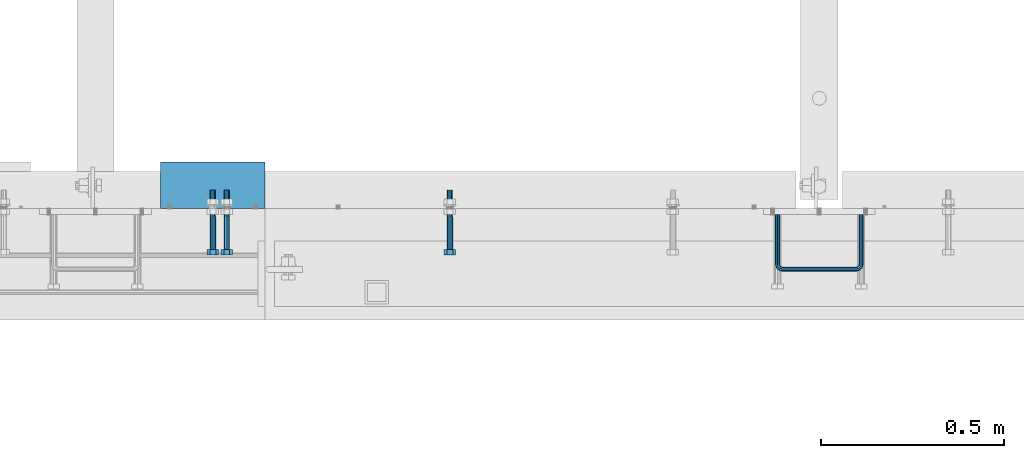
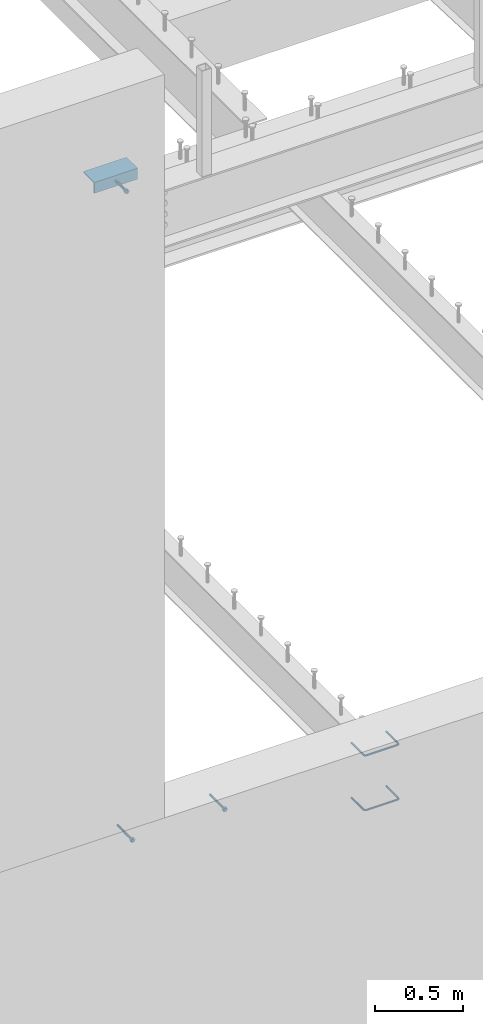
# One storey, part 400 of 975: 6 beams.
"""IFC2X3 building model written with IfcOpenShell, lengths in millimetres."""

from ifc_helpers import new_model, si_unit, frame, origin_with_axes, place, context, subcontext, project, spatial, faceted_brep, material, type_object, element, save


model = new_model("IFC2X3")

# Units and contexts
model_context = context("Model", 3, precision=1e-05, world=origin_with_axes())
body_context = subcontext(model_context, "Body", "Model", "MODEL_VIEW")
ifc_project = project(units=[si_unit("LENGTHUNIT", "METRE", prefix="MILLI"), si_unit("AREAUNIT", "SQUARE_METRE"), si_unit("VOLUMEUNIT", "CUBIC_METRE"), si_unit("MASSUNIT", "GRAM", prefix="KILO"), si_unit("TIMEUNIT", "SECOND"), si_unit("PLANEANGLEUNIT", "RADIAN"), si_unit("SOLIDANGLEUNIT", "STERADIAN"), si_unit("THERMODYNAMICTEMPERATUREUNIT", "DEGREE_CELSIUS"), si_unit("LUMINOUSINTENSITYUNIT", "LUMEN")], contexts=[model_context])

# Site, building, storey
site_placement = place(None, origin_with_axes())
site = spatial("IfcSite", under=ifc_project, at=site_placement, CompositionType="ELEMENT")
building_placement = place(site_placement, origin_with_axes())
building = spatial("IfcBuilding", under=site, at=building_placement, Name="Undefined", CompositionType="ELEMENT")
storey_placement = place(building_placement, origin_with_axes())
storey = spatial("IfcBuildingStorey", under=building, at=storey_placement, Name="Undefined", CompositionType="ELEMENT", Elevation=0.0)

# Beams
ifc_material_1 = material(Name="STEEL/F1554-36")
beam_type_1 = type_object("IfcBeamType", PredefinedType="NOTDEFINED")
beam_1_placement = place(storey_placement, frame((11830.0499551931, 282.575168162621, 8420.10000031656), z_axis=(0.0, 0.0, -1.0), x_axis=(-1.08499996598766e-06, -0.999999999999411, 3.99994337564561e-09)))
element("IfcBeam", 1, at=beam_1_placement, inside=storey, type_object=beam_type_1, material=ifc_material_1, Name="HEADED_ANCHOR_BOLT", context=body_context, shape_type="Brep", body=[
    faceted_brep([(88.9000000184824, 7.94000001861696, -13.7499999799138), (88.8999999527368, 15.8800000758411, 2.00943759409711e-08), (104.774999952569, 15.8800001213949, 6.97191353538074e-08), (104.775000018315, 7.94000006417082, -13.7499999302891), (88.900000064019, -7.94000009583215, -13.7499999799147), (104.775000063852, -7.9400000502792, -13.74999993029), (88.9000000438027, -15.880000153059, 2.00925569515675e-08), (104.775000043643, -15.8800001075042, 6.9716406869702e-08), (88.8999999780608, -7.94000009583488, 13.7500000200998), (104.774999977893, -7.94000005028101, 13.7500000697237), (88.8999999325279, 7.94000001861514, 13.7500000201007), (104.774999932361, 7.940000064169, 13.7500000697246), (88.9000000119959, 3.78780480527439, -7.86545778426807), (88.8999999957159, 6.82538844544797, -5.4430656647246), (88.8999999799416, 8.51112018845743, -1.94260763148395), (88.8999999677944, 8.51112018845652, 1.94260767167179), (88.8999999616899, 6.82538844544615, 5.44306570491244), (88.8999999628249, 3.78780480527257, 7.86545782445592), (88.8999999709849, -3.86089595849626e-08, 8.72999956233434), (88.8999999845473, -3.7878048824914, 7.8654578244541), (88.9000000008309, -6.82538852266407, 5.44306570491153), (88.9000000166052, -8.51112026567444, 1.94260767166998), (88.9000000287488, -8.51112026567353, -1.94260763148577), (88.9000000348606, -6.82538852266407, -5.44306566472642), (88.9000000337182, -3.78780488248958, -7.86545778426898), (88.9000000255583, -3.86080500902608e-08, -8.72999952214832), (104.775000025395, 6.94581103743985e-09, -8.72999947252447), (104.775000011829, 3.78780485082825, -7.86545773464422), (104.774999995549, 6.82538849100092, -5.44306561510075), (104.774999979774, 8.51112023401038, -1.9426075818601), (104.774999967627, 8.51112023401038, 1.94260772129564), (104.774999961523, 6.82538849100092, 5.44306575453629), (104.774999962658, 3.78780485082643, 7.86545787407977), (104.774999970818, 6.94399204803631e-09, 8.7299996119591), (104.77499998438, -3.78780483693754, 7.86545787407886), (104.775000000664, -6.82538847711112, 5.44306575453538), (104.775000016438, -8.51112022012057, 1.94260772129473), (104.775000028581, -8.51112022012057, -1.94260758186101), (104.775000034693, -6.82538847711021, -5.44306561510166), (104.775000033551, -3.78780483693663, -7.86545773464422), (-2.99107341561466e-07, -5.61266007567065, 5.61266007566792), (-4.22995071858168e-07, -7.93750000000728, 0.0), (104.774999998088, -7.93749999999, -4.45652403868735e-11), (104.774999998088, -5.61266007565791, 5.61266007562426), (-1.09139364212751e-11, 1.81898940354586e-12, 7.9375), (104.774999998095, 1.18234311230481e-11, 7.93749999995816), (2.99089151667431e-07, 5.61266007567428, 5.61266007566792), (104.774999998102, 5.61266007568065, 5.61266007562517), (4.22980519942939e-07, 7.93750000001091, 0.0), (104.77499999811, 7.93750000001364, -4.36557456851006e-11), (2.99089151667431e-07, 5.61266007567428, -5.61266007566792), (104.774999998102, 5.61266007568156, -5.61266007571339), (-1.09139364212751e-11, 1.81898940354586e-12, -7.9375), (104.774999998099, 1.2732925824821e-11, -7.93750000004547), (-73.0249999592124, 5.05157065939329, -5.0515715445581), (-73.0249999269472, -1.85405951924622e-07, -7.14400069976364), (-73.0249999328516, -5.0515710302052, -5.05157154455992), (-73.0249999734697, -7.14400018541073, -6.9975976657588e-07), (-73.0250000250016, -5.05157103020611, 5.05157014504039), (-73.0250000572705, -1.85406861419324e-07, 7.1439993002441), (-73.0250000513661, 5.05157065939238, 5.05157014503948), (-73.025000010748, 7.14399981459792, -6.99758857081179e-07), (0.00625003290042514, 5.05157085007795, -5.05157087849238), (0.00625006516929716, 5.27870724909008e-09, -7.1440000336961), (0.00625005926485755, -5.05157083952145, -5.05157087849329), (0.00625001864682417, -7.14399999472516, -3.36940502165817e-08), (0.00624996711121639, -5.05157083952145, 5.05157081110519), (0.00624993484598235, 5.2777977543883e-09, 7.14399996631164), (0.00624994074678398, 5.05157085007704, 5.05157081110701), (0.00624998136845534, 7.14400000528167, -3.36922312271781e-08), (-2.99107341561466e-07, -5.61266007567065, -5.61266007566792), (104.774999998092, -5.612660075657, -5.6126600757143)], [[[0, 1, 2, 3]], [[4, 0, 3, 5]], [[6, 4, 5, 7]], [[8, 6, 7, 9]], [[10, 8, 9, 11]], [[0, 4, 6, 8, 10, 1], [12, 13, 14, 15, 16, 17, 18, 19, 20, 21, 22, 23, 24, 25]], [[12, 25, 26, 27]], [[13, 12, 27, 28]], [[14, 13, 28, 29]], [[15, 14, 29, 30]], [[16, 15, 30, 31]], [[17, 16, 31, 32]], [[18, 17, 32, 33]], [[19, 18, 33, 34]], [[20, 19, 34, 35]], [[21, 20, 35, 36]], [[22, 21, 36, 37]], [[23, 22, 37, 38]], [[24, 23, 38, 39]], [[25, 24, 39, 26]], [[9, 7, 5, 3, 2, 11], [38, 37, 36, 35, 34, 33, 32, 31, 30, 29, 28, 27, 26, 39]], [[1, 10, 11, 2]], [[40, 41, 42, 43]], [[44, 40, 43, 45]], [[46, 44, 45, 47]], [[48, 46, 47, 49]], [[50, 48, 49, 51]], [[52, 50, 51, 53]], [[54, 55, 56, 57, 58, 59, 60, 61]], [[55, 54, 62, 63]], [[56, 55, 63, 64]], [[57, 56, 64, 65]], [[58, 57, 65, 66]], [[59, 58, 66, 67]], [[60, 59, 67, 68]], [[61, 60, 68, 69]], [[54, 61, 69, 62]], [[40, 44, 46, 48, 50, 52, 70, 41], [68, 67, 66, 65, 64, 63, 62, 69]], [[41, 70, 71, 42]], [[53, 51, 49, 47, 45, 43, 42, 71]], [[70, 52, 53, 71]]]),
])
beam_2_placement = place(storey_placement, frame((11868.15, 282.574999999997, 3886.2), z_axis=(0.0, 0.0, -1.0), x_axis=(0.0, -1.0, 0.0)))
element("IfcBeam", 2, at=beam_2_placement, inside=storey, type_object=beam_type_1, material=ifc_material_1, Name="HEADED_ANCHOR_BOLT", context=body_context, shape_type="Brep", body=[
    faceted_brep([(88.9000000184824, 7.94000001861696, -13.7499999799138), (88.8999999527368, 15.8800000758411, 2.00943759409711e-08), (104.774999952569, 15.8800001213949, 6.97191353538074e-08), (104.775000018315, 7.94000006417082, -13.7499999302891), (88.900000064019, -7.94000009583215, -13.7499999799147), (104.775000063852, -7.9400000502792, -13.74999993029), (88.9000000438027, -15.880000153059, 2.00925569515675e-08), (104.775000043643, -15.8800001075042, 6.9716406869702e-08), (88.8999999780608, -7.94000009583488, 13.7500000200998), (104.774999977893, -7.94000005028101, 13.7500000697237), (88.8999999325279, 7.94000001861514, 13.7500000201007), (104.774999932361, 7.940000064169, 13.7500000697246), (88.9000000119959, 3.78780480527439, -7.86545778426807), (88.8999999957159, 6.82538844544797, -5.4430656647246), (88.8999999799416, 8.51112018845743, -1.94260763148395), (88.8999999677944, 8.51112018845652, 1.94260767167179), (88.8999999616899, 6.82538844544615, 5.44306570491244), (88.8999999628249, 3.78780480527257, 7.86545782445592), (88.8999999709849, -3.86089595849626e-08, 8.72999956233434), (88.8999999845473, -3.7878048824914, 7.8654578244541), (88.9000000008309, -6.82538852266407, 5.44306570491153), (88.9000000166052, -8.51112026567444, 1.94260767166998), (88.9000000287488, -8.51112026567353, -1.94260763148577), (88.9000000348606, -6.82538852266407, -5.44306566472642), (88.9000000337182, -3.78780488248958, -7.86545778426898), (88.9000000255583, -3.86080500902608e-08, -8.72999952214832), (104.775000025395, 6.94581103743985e-09, -8.72999947252447), (104.775000011829, 3.78780485082825, -7.86545773464422), (104.774999995549, 6.82538849100092, -5.44306561510075), (104.774999979774, 8.51112023401038, -1.9426075818601), (104.774999967627, 8.51112023401038, 1.94260772129564), (104.774999961523, 6.82538849100092, 5.44306575453629), (104.774999962658, 3.78780485082643, 7.86545787407977), (104.774999970818, 6.94399204803631e-09, 8.7299996119591), (104.77499998438, -3.78780483693754, 7.86545787407886), (104.775000000664, -6.82538847711112, 5.44306575453538), (104.775000016438, -8.51112022012057, 1.94260772129473), (104.775000028581, -8.51112022012057, -1.94260758186101), (104.775000034693, -6.82538847711021, -5.44306561510166), (104.775000033551, -3.78780483693663, -7.86545773464422), (-2.99107341561466e-07, -5.61266007567065, 5.61266007566792), (-4.22995071858168e-07, -7.93750000000728, 0.0), (104.774999998088, -7.93749999999, -4.45652403868735e-11), (104.774999998088, -5.61266007565791, 5.61266007562426), (-1.09139364212751e-11, 1.81898940354586e-12, 7.9375), (104.774999998095, 1.18234311230481e-11, 7.93749999995816), (2.99089151667431e-07, 5.61266007567428, 5.61266007566792), (104.774999998102, 5.61266007568065, 5.61266007562517), (4.22980519942939e-07, 7.93750000001091, 0.0), (104.77499999811, 7.93750000001364, -4.36557456851006e-11), (2.99089151667431e-07, 5.61266007567428, -5.61266007566792), (104.774999998102, 5.61266007568156, -5.61266007571339), (-1.09139364212751e-11, 1.81898940354586e-12, -7.9375), (104.774999998099, 1.2732925824821e-11, -7.93750000004547), (-73.0249999592124, 5.05157065939329, -5.0515715445581), (-73.0249999269472, -1.85405951924622e-07, -7.14400069976364), (-73.0249999328516, -5.0515710302052, -5.05157154455992), (-73.0249999734697, -7.14400018541073, -6.9975976657588e-07), (-73.0250000250016, -5.05157103020611, 5.05157014504039), (-73.0250000572705, -1.85406861419324e-07, 7.1439993002441), (-73.0250000513661, 5.05157065939238, 5.05157014503948), (-73.025000010748, 7.14399981459792, -6.99758857081179e-07), (0.00625003290042514, 5.05157085007795, -5.05157087849238), (0.00625006516929716, 5.27870724909008e-09, -7.1440000336961), (0.00625005926485755, -5.05157083952145, -5.05157087849329), (0.00625001864682417, -7.14399999472516, -3.36940502165817e-08), (0.00624996711121639, -5.05157083952145, 5.05157081110519), (0.00624993484598235, 5.2777977543883e-09, 7.14399996631164), (0.00624994074678398, 5.05157085007704, 5.05157081110701), (0.00624998136845534, 7.14400000528167, -3.36922312271781e-08), (-2.99107341561466e-07, -5.61266007567065, -5.61266007566792), (104.774999998092, -5.612660075657, -5.6126600757143)], [[[0, 1, 2, 3]], [[4, 0, 3, 5]], [[6, 4, 5, 7]], [[8, 6, 7, 9]], [[10, 8, 9, 11]], [[0, 4, 6, 8, 10, 1], [12, 13, 14, 15, 16, 17, 18, 19, 20, 21, 22, 23, 24, 25]], [[12, 25, 26, 27]], [[13, 12, 27, 28]], [[14, 13, 28, 29]], [[15, 14, 29, 30]], [[16, 15, 30, 31]], [[17, 16, 31, 32]], [[18, 17, 32, 33]], [[19, 18, 33, 34]], [[20, 19, 34, 35]], [[21, 20, 35, 36]], [[22, 21, 36, 37]], [[23, 22, 37, 38]], [[24, 23, 38, 39]], [[25, 24, 39, 26]], [[9, 7, 5, 3, 2, 11], [38, 37, 36, 35, 34, 33, 32, 31, 30, 29, 28, 27, 26, 39]], [[1, 10, 11, 2]], [[40, 41, 42, 43]], [[44, 40, 43, 45]], [[46, 44, 45, 47]], [[48, 46, 47, 49]], [[50, 48, 49, 51]], [[52, 50, 51, 53]], [[54, 55, 56, 57, 58, 59, 60, 61]], [[55, 54, 62, 63]], [[56, 55, 63, 64]], [[57, 56, 64, 65]], [[58, 57, 65, 66]], [[59, 58, 66, 67]], [[60, 59, 67, 68]], [[61, 60, 68, 69]], [[54, 61, 69, 62]], [[40, 44, 46, 48, 50, 52, 70, 41], [68, 67, 66, 65, 64, 63, 62, 69]], [[41, 70, 71, 42]], [[53, 51, 49, 47, 45, 43, 42, 71]], [[70, 52, 53, 71]]]),
])
beam_3_placement = place(storey_placement, frame((12477.75, 282.574999999997, 3886.2), z_axis=(0.0, 0.0, 1.0), x_axis=(0.0, -1.0, 0.0)))
element("IfcBeam", 3, at=beam_3_placement, inside=storey, type_object=beam_type_1, material=ifc_material_1, Name="HEADED_ANCHOR_BOLT", context=body_context, shape_type="Brep", body=[
    faceted_brep([(88.9000000184824, 7.94000001861696, -13.7499999799138), (88.8999999527368, 15.8800000758411, 2.00943759409711e-08), (104.774999952569, 15.8800001213949, 6.97191353538074e-08), (104.775000018315, 7.94000006417082, -13.7499999302891), (88.900000064019, -7.94000009583215, -13.7499999799147), (104.775000063852, -7.9400000502792, -13.74999993029), (88.9000000438027, -15.880000153059, 2.00925569515675e-08), (104.775000043643, -15.8800001075042, 6.9716406869702e-08), (88.8999999780608, -7.94000009583488, 13.7500000200998), (104.774999977893, -7.94000005028101, 13.7500000697237), (88.8999999325279, 7.94000001861514, 13.7500000201007), (104.774999932361, 7.940000064169, 13.7500000697246), (88.9000000119959, 3.78780480527439, -7.86545778426807), (88.8999999957159, 6.82538844544797, -5.4430656647246), (88.8999999799416, 8.51112018845743, -1.94260763148395), (88.8999999677944, 8.51112018845652, 1.94260767167179), (88.8999999616899, 6.82538844544615, 5.44306570491244), (88.8999999628249, 3.78780480527257, 7.86545782445592), (88.8999999709849, -3.86089595849626e-08, 8.72999956233434), (88.8999999845473, -3.7878048824914, 7.8654578244541), (88.9000000008309, -6.82538852266407, 5.44306570491153), (88.9000000166052, -8.51112026567444, 1.94260767166998), (88.9000000287488, -8.51112026567353, -1.94260763148577), (88.9000000348606, -6.82538852266407, -5.44306566472642), (88.9000000337182, -3.78780488248958, -7.86545778426898), (88.9000000255583, -3.86080500902608e-08, -8.72999952214832), (104.775000025395, 6.94581103743985e-09, -8.72999947252447), (104.775000011829, 3.78780485082825, -7.86545773464422), (104.774999995549, 6.82538849100092, -5.44306561510075), (104.774999979774, 8.51112023401038, -1.9426075818601), (104.774999967627, 8.51112023401038, 1.94260772129564), (104.774999961523, 6.82538849100092, 5.44306575453629), (104.774999962658, 3.78780485082643, 7.86545787407977), (104.774999970818, 6.94399204803631e-09, 8.7299996119591), (104.77499998438, -3.78780483693754, 7.86545787407886), (104.775000000664, -6.82538847711112, 5.44306575453538), (104.775000016438, -8.51112022012057, 1.94260772129473), (104.775000028581, -8.51112022012057, -1.94260758186101), (104.775000034693, -6.82538847711021, -5.44306561510166), (104.775000033551, -3.78780483693663, -7.86545773464422), (-2.99107341561466e-07, -5.61266007567065, 5.61266007566792), (-4.22995071858168e-07, -7.93750000000728, 0.0), (104.774999998088, -7.93749999999, -4.45652403868735e-11), (104.774999998088, -5.61266007565791, 5.61266007562426), (-1.09139364212751e-11, 1.81898940354586e-12, 7.9375), (104.774999998095, 1.18234311230481e-11, 7.93749999995816), (2.99089151667431e-07, 5.61266007567428, 5.61266007566792), (104.774999998102, 5.61266007568065, 5.61266007562517), (4.22980519942939e-07, 7.93750000001091, 0.0), (104.77499999811, 7.93750000001364, -4.36557456851006e-11), (2.99089151667431e-07, 5.61266007567428, -5.61266007566792), (104.774999998102, 5.61266007568156, -5.61266007571339), (-1.09139364212751e-11, 1.81898940354586e-12, -7.9375), (104.774999998099, 1.2732925824821e-11, -7.93750000004547), (-73.0249999592124, 5.05157065939329, -5.0515715445581), (-73.0249999269472, -1.85405951924622e-07, -7.14400069976364), (-73.0249999328516, -5.0515710302052, -5.05157154455992), (-73.0249999734697, -7.14400018541073, -6.9975976657588e-07), (-73.0250000250016, -5.05157103020611, 5.05157014504039), (-73.0250000572705, -1.85406861419324e-07, 7.1439993002441), (-73.0250000513661, 5.05157065939238, 5.05157014503948), (-73.025000010748, 7.14399981459792, -6.99758857081179e-07), (0.00625003290042514, 5.05157085007795, -5.05157087849238), (0.00625006516929716, 5.27870724909008e-09, -7.1440000336961), (0.00625005926485755, -5.05157083952145, -5.05157087849329), (0.00625001864682417, -7.14399999472516, -3.36940502165817e-08), (0.00624996711121639, -5.05157083952145, 5.05157081110519), (0.00624993484598235, 5.2777977543883e-09, 7.14399996631164), (0.00624994074678398, 5.05157085007704, 5.05157081110701), (0.00624998136845534, 7.14400000528167, -3.36922312271781e-08), (-2.99107341561466e-07, -5.61266007567065, -5.61266007566792), (104.774999998092, -5.612660075657, -5.6126600757143)], [[[0, 1, 2, 3]], [[4, 0, 3, 5]], [[6, 4, 5, 7]], [[8, 6, 7, 9]], [[10, 8, 9, 11]], [[0, 4, 6, 8, 10, 1], [12, 13, 14, 15, 16, 17, 18, 19, 20, 21, 22, 23, 24, 25]], [[12, 25, 26, 27]], [[13, 12, 27, 28]], [[14, 13, 28, 29]], [[15, 14, 29, 30]], [[16, 15, 30, 31]], [[17, 16, 31, 32]], [[18, 17, 32, 33]], [[19, 18, 33, 34]], [[20, 19, 34, 35]], [[21, 20, 35, 36]], [[22, 21, 36, 37]], [[23, 22, 37, 38]], [[24, 23, 38, 39]], [[25, 24, 39, 26]], [[9, 7, 5, 3, 2, 11], [38, 37, 36, 35, 34, 33, 32, 31, 30, 29, 28, 27, 26, 39]], [[1, 10, 11, 2]], [[40, 41, 42, 43]], [[44, 40, 43, 45]], [[46, 44, 45, 47]], [[48, 46, 47, 49]], [[50, 48, 49, 51]], [[52, 50, 51, 53]], [[54, 55, 56, 57, 58, 59, 60, 61]], [[55, 54, 62, 63]], [[56, 55, 63, 64]], [[57, 56, 64, 65]], [[58, 57, 65, 66]], [[59, 58, 66, 67]], [[60, 59, 67, 68]], [[61, 60, 68, 69]], [[54, 61, 69, 62]], [[40, 44, 46, 48, 50, 52, 70, 41], [68, 67, 66, 65, 64, 63, 62, 69]], [[41, 70, 71, 42]], [[53, 51, 49, 47, 45, 43, 42, 71]], [[70, 52, 53, 71]]]),
])
ifc_material_2 = material(Name="STEEL/A706")
beam_type_2 = type_object("IfcBeamType", Name="#4 TIE", PredefinedType="NOTDEFINED")
beam_4_placement = place(storey_placement, frame((13601.7000030518, 288.924999999996, 3971.925), z_axis=(-0.999999999999998, 6.90000001668524e-08, 0.0), x_axis=(0.0, -1.0, 0.0)))
element("IfcBeam", 4, at=beam_4_placement, inside=storey, type_object=beam_type_2, material=ifc_material_2, Name="TIE ROD", ObjectType="#4 TIE", context=body_context, shape_type="Brep", body=[
    faceted_brep([(0.0, -6.34999999998763, -3.63797880709171e-12), (0.0, -4.49012806052269, -4.49012806054634), (136.525006144455, -4.49012806053452, -4.49012811661669), (136.525006146271, -6.35000000000036, -5.60821717954241e-08), (0.0, 7.27595761418343e-12, -6.35000000000764), (136.525006143703, 0.0, -6.35000005608254), (0.0, 4.49012806053724, -4.49012806053906), (136.525006144455, 4.49012806053452, -4.49012811661669), (0.0, 6.34999999999491, 5.45696821063757e-12), (136.525006146271, 6.35000000000036, -5.60821717954241e-08), (0.0, 4.49012806052633, 4.49012806054634), (136.525006148087, 4.49012806053452, 4.49012800445234), (0.0, 0.0, 6.35000000000764), (136.525006148839, 0.0, 6.34999994391819), (0.0, -4.49012806053361, 4.49012806053543), (136.525006148087, -4.49012806053452, 4.49012800445234), (146.050006113442, 0.0, -3.79778399058796), (145.120070138105, -4.49012806053452, -2.1870876464609), (142.875006094308, -6.35000000000036, 1.70147731239558), (140.62994205051, -4.49012806053452, 5.59004227125297), (139.700006075173, 0.0, 7.20073861538003), (140.62994205051, 4.49012806053452, 5.59004227125297), (142.875006094308, 6.35000000000036, 1.70147731239558), (145.120070138105, 4.49012806053452, -2.1870876464609), (151.412093644245, 4.49012806053452, 4.10493592790226), (153.022789998455, 0.0, 3.1749999700296), (147.523528661045, 6.35000000000036, 6.34999992953635), (143.634963677846, 4.49012806053452, 8.59506393117135), (142.024267323636, 0.0, 9.5249998890431), (143.634963677846, -4.49012806053452, 8.59506393117135), (147.523528661045, -6.35000000000036, 6.34999992953635), (151.412093644245, -4.49012806053452, 4.10493592790226), (153.715134021207, 4.49012806053452, 12.6999999465306), (155.575005960673, 0.0, 12.6999999674508), (149.225005960672, 6.35000000000036, 12.6999998960273), (144.734877900137, 4.49012806053452, 12.699999845524), (142.875005960672, 0.0, 12.6999998246056), (144.734877900137, -4.49012806053452, 12.699999845524), (149.225005960671, -6.35000000000036, 12.6999998960273), (153.715134021207, -4.49012806053452, 12.6999999465306), (153.71513173569, -4.49012806053452, 215.900003176369), (149.225003675155, -6.35000000000036, 215.900003125867), (155.575003675155, 0.0, 215.900003197289), (153.71513173569, 4.49012806053452, 215.900003176369), (149.225003675155, 6.35000000000036, 215.900003125867), (144.734875614621, 4.49012806053452, 215.900003075363), (142.875003675155, 0.0, 215.900003054444), (144.734875614621, -4.49012806053452, 215.900003075363), (153.022787648382, 0.0, 225.425002877988), (151.412091300475, -4.49012806053452, 224.495066909199), (147.523526332491, -6.35000000000036, 222.25000288121), (143.634961364508, -4.49012806053452, 220.004938853222), (142.024265016601, 0.0, 219.075002884432), (143.634961364508, 4.49012806053452, 220.004938853222), (147.523526332491, 6.35000000000036, 222.25000288121), (151.412091300475, 4.49012806053452, 224.495066909199), (145.120067985683, 4.49012806053452, 230.787090305822), (146.05000397542, 0.0, 232.397786641635), (142.875003907121, 6.35000000000036, 226.898525367037), (140.629939828559, 4.49012806053452, 223.00996042825), (139.700003838822, 0.0, 221.399264092438), (140.629939828559, -4.49012806053452, 223.00996042825), (142.875003907121, -6.35000000000036, 226.898525367037), (145.120067985683, -4.49012806053452, 230.787090305822), (136.525004282814, 4.49012806053452, 233.090130852819), (136.525004327922, 0.0, 234.950002792285), (136.525004173912, 6.35000000000036, 228.600002792285), (136.52500406501, 4.49012806053452, 224.10987473175), (136.525004019901, 0.0, 222.250002792285), (136.52500406501, -4.49012806053452, 224.10987473175), (136.525004173912, -6.35000000000036, 228.600002792286), (136.525004282814, -4.49012806053452, 233.090130852819), (3.32236731992452e-06, -4.49012806053452, 233.090134164055), (3.21346533382894e-06, -6.35000000000036, 228.60000610352), (3.36747552864836e-06, 0.0, 234.95000610352), (3.32236731992452e-06, 4.49012806053452, 233.090134164055), (3.21346533382894e-06, 6.35000000000036, 228.60000610352), (3.104562892986e-06, 4.49012806053452, 224.109878042986), (3.05945422951481e-06, 0.0, 222.25000610352), (3.104562892986e-06, -4.49012806053452, 224.109878042986)], [[[0, 1, 2, 3]], [[1, 4, 5, 2]], [[4, 6, 7, 5]], [[6, 8, 9, 7]], [[8, 10, 11, 9]], [[10, 12, 13, 11]], [[12, 14, 15, 13]], [[14, 0, 3, 15]], [[14, 12, 10, 8, 6, 4, 1, 0]], [[2, 5, 16, 17]], [[3, 2, 17, 18]], [[15, 3, 18, 19]], [[13, 15, 19, 20]], [[11, 13, 20, 21]], [[9, 11, 21, 22]], [[7, 9, 22, 23]], [[5, 7, 23, 16]], [[23, 24, 25, 16]], [[22, 26, 24, 23]], [[21, 27, 26, 22]], [[20, 28, 27, 21]], [[19, 29, 28, 20]], [[18, 30, 29, 19]], [[17, 31, 30, 18]], [[16, 25, 31, 17]], [[24, 32, 33, 25]], [[26, 34, 32, 24]], [[27, 35, 34, 26]], [[28, 36, 35, 27]], [[29, 37, 36, 28]], [[30, 38, 37, 29]], [[31, 39, 38, 30]], [[25, 33, 39, 31]], [[38, 39, 40, 41]], [[39, 33, 42, 40]], [[33, 32, 43, 42]], [[32, 34, 44, 43]], [[34, 35, 45, 44]], [[35, 36, 46, 45]], [[36, 37, 47, 46]], [[37, 38, 41, 47]], [[40, 42, 48, 49]], [[41, 40, 49, 50]], [[47, 41, 50, 51]], [[46, 47, 51, 52]], [[45, 46, 52, 53]], [[44, 45, 53, 54]], [[43, 44, 54, 55]], [[42, 43, 55, 48]], [[55, 56, 57, 48]], [[54, 58, 56, 55]], [[53, 59, 58, 54]], [[52, 60, 59, 53]], [[51, 61, 60, 52]], [[50, 62, 61, 51]], [[49, 63, 62, 50]], [[48, 57, 63, 49]], [[56, 64, 65, 57]], [[58, 66, 64, 56]], [[59, 67, 66, 58]], [[60, 68, 67, 59]], [[61, 69, 68, 60]], [[62, 70, 69, 61]], [[63, 71, 70, 62]], [[57, 65, 71, 63]], [[70, 71, 72, 73]], [[71, 65, 74, 72]], [[65, 64, 75, 74]], [[64, 66, 76, 75]], [[66, 67, 77, 76]], [[67, 68, 78, 77]], [[68, 69, 79, 78]], [[69, 70, 73, 79]], [[74, 75, 76, 77, 78, 79, 73, 72]]]),
])
beam_5_placement = place(storey_placement, frame((13601.7000030518, 288.924999999996, 3590.92498779297), z_axis=(-0.999999999999998, 6.90000001668524e-08, 0.0), x_axis=(0.0, -1.0, 0.0)))
element("IfcBeam", 5, at=beam_5_placement, inside=storey, type_object=beam_type_2, material=ifc_material_2, Name="TIE ROD", ObjectType="#4 TIE", context=body_context, shape_type="Brep", body=[
    faceted_brep([(0.0, -6.34999999998763, -3.63797880709171e-12), (0.0, -4.49012806052269, -4.49012806054634), (136.525006144455, -4.49012806053452, -4.49012811661669), (136.525006146271, -6.35000000000036, -5.60821717954241e-08), (0.0, 7.27595761418343e-12, -6.35000000000764), (136.525006143703, 0.0, -6.35000005608254), (0.0, 4.49012806053724, -4.49012806053906), (136.525006144455, 4.49012806053452, -4.49012811661669), (0.0, 6.34999999999491, 5.45696821063757e-12), (136.525006146271, 6.35000000000036, -5.60821717954241e-08), (0.0, 4.49012806052633, 4.49012806054634), (136.525006148087, 4.49012806053452, 4.49012800445234), (0.0, 0.0, 6.35000000000764), (136.525006148839, 0.0, 6.34999994391819), (0.0, -4.49012806053361, 4.49012806053543), (136.525006148087, -4.49012806053452, 4.49012800445234), (146.050006113442, 0.0, -3.79778399058796), (145.120070138105, -4.49012806053452, -2.1870876464609), (142.875006094308, -6.35000000000036, 1.70147731239558), (140.62994205051, -4.49012806053452, 5.59004227125297), (139.700006075173, 0.0, 7.20073861538003), (140.62994205051, 4.49012806053452, 5.59004227125297), (142.875006094308, 6.35000000000036, 1.70147731239558), (145.120070138105, 4.49012806053452, -2.1870876464609), (151.412093644245, 4.49012806053452, 4.10493592790226), (153.022789998455, 0.0, 3.1749999700296), (147.523528661045, 6.35000000000036, 6.34999992953635), (143.634963677846, 4.49012806053452, 8.59506393117135), (142.024267323636, 0.0, 9.5249998890431), (143.634963677846, -4.49012806053452, 8.59506393117135), (147.523528661045, -6.35000000000036, 6.34999992953635), (151.412093644245, -4.49012806053452, 4.10493592790226), (153.715134021207, 4.49012806053452, 12.6999999465306), (155.575005960673, 0.0, 12.6999999674508), (149.225005960672, 6.35000000000036, 12.6999998960273), (144.734877900137, 4.49012806053452, 12.699999845524), (142.875005960672, 0.0, 12.6999998246056), (144.734877900137, -4.49012806053452, 12.699999845524), (149.225005960671, -6.35000000000036, 12.6999998960273), (153.715134021207, -4.49012806053452, 12.6999999465306), (153.71513173569, -4.49012806053452, 215.900003176369), (149.225003675155, -6.35000000000036, 215.900003125867), (155.575003675155, 0.0, 215.900003197289), (153.71513173569, 4.49012806053452, 215.900003176369), (149.225003675155, 6.35000000000036, 215.900003125867), (144.734875614621, 4.49012806053452, 215.900003075363), (142.875003675155, 0.0, 215.900003054444), (144.734875614621, -4.49012806053452, 215.900003075363), (153.022787648382, 0.0, 225.425002877988), (151.412091300475, -4.49012806053452, 224.495066909199), (147.523526332491, -6.35000000000036, 222.25000288121), (143.634961364508, -4.49012806053452, 220.004938853222), (142.024265016601, 0.0, 219.075002884432), (143.634961364508, 4.49012806053452, 220.004938853222), (147.523526332491, 6.35000000000036, 222.25000288121), (151.412091300475, 4.49012806053452, 224.495066909199), (145.120067985683, 4.49012806053452, 230.787090305822), (146.05000397542, 0.0, 232.397786641635), (142.875003907121, 6.35000000000036, 226.898525367037), (140.629939828559, 4.49012806053452, 223.00996042825), (139.700003838822, 0.0, 221.399264092438), (140.629939828559, -4.49012806053452, 223.00996042825), (142.875003907121, -6.35000000000036, 226.898525367037), (145.120067985683, -4.49012806053452, 230.787090305822), (136.525004282814, 4.49012806053452, 233.090130852819), (136.525004327922, 0.0, 234.950002792285), (136.525004173912, 6.35000000000036, 228.600002792285), (136.52500406501, 4.49012806053452, 224.10987473175), (136.525004019901, 0.0, 222.250002792285), (136.52500406501, -4.49012806053452, 224.10987473175), (136.525004173912, -6.35000000000036, 228.600002792286), (136.525004282814, -4.49012806053452, 233.090130852819), (3.32236731992452e-06, -4.49012806053452, 233.090134164055), (3.21346533382894e-06, -6.35000000000036, 228.60000610352), (3.36747552864836e-06, 0.0, 234.95000610352), (3.32236731992452e-06, 4.49012806053452, 233.090134164055), (3.21346533382894e-06, 6.35000000000036, 228.60000610352), (3.104562892986e-06, 4.49012806053452, 224.109878042986), (3.05945422951481e-06, 0.0, 222.25000610352), (3.104562892986e-06, -4.49012806053452, 224.109878042986)], [[[0, 1, 2, 3]], [[1, 4, 5, 2]], [[4, 6, 7, 5]], [[6, 8, 9, 7]], [[8, 10, 11, 9]], [[10, 12, 13, 11]], [[12, 14, 15, 13]], [[14, 0, 3, 15]], [[14, 12, 10, 8, 6, 4, 1, 0]], [[2, 5, 16, 17]], [[3, 2, 17, 18]], [[15, 3, 18, 19]], [[13, 15, 19, 20]], [[11, 13, 20, 21]], [[9, 11, 21, 22]], [[7, 9, 22, 23]], [[5, 7, 23, 16]], [[23, 24, 25, 16]], [[22, 26, 24, 23]], [[21, 27, 26, 22]], [[20, 28, 27, 21]], [[19, 29, 28, 20]], [[18, 30, 29, 19]], [[17, 31, 30, 18]], [[16, 25, 31, 17]], [[24, 32, 33, 25]], [[26, 34, 32, 24]], [[27, 35, 34, 26]], [[28, 36, 35, 27]], [[29, 37, 36, 28]], [[30, 38, 37, 29]], [[31, 39, 38, 30]], [[25, 33, 39, 31]], [[38, 39, 40, 41]], [[39, 33, 42, 40]], [[33, 32, 43, 42]], [[32, 34, 44, 43]], [[34, 35, 45, 44]], [[35, 36, 46, 45]], [[36, 37, 47, 46]], [[37, 38, 41, 47]], [[40, 42, 48, 49]], [[41, 40, 49, 50]], [[47, 41, 50, 51]], [[46, 47, 51, 52]], [[45, 46, 52, 53]], [[44, 45, 53, 54]], [[43, 44, 54, 55]], [[42, 43, 55, 48]], [[55, 56, 57, 48]], [[54, 58, 56, 55]], [[53, 59, 58, 54]], [[52, 60, 59, 53]], [[51, 61, 60, 52]], [[50, 62, 61, 51]], [[49, 63, 62, 50]], [[48, 57, 63, 49]], [[56, 64, 65, 57]], [[58, 66, 64, 56]], [[59, 67, 66, 58]], [[60, 68, 67, 59]], [[61, 69, 68, 60]], [[62, 70, 69, 61]], [[63, 71, 70, 62]], [[57, 65, 71, 63]], [[70, 71, 72, 73]], [[71, 65, 74, 72]], [[65, 64, 75, 74]], [[64, 66, 76, 75]], [[66, 67, 77, 76]], [[67, 68, 78, 77]], [[68, 69, 79, 78]], [[69, 70, 73, 79]], [[74, 75, 76, 77, 78, 79, 73, 72]]]),
])
ifc_material_3 = material(Name="STEEL/A36")
beam_type_3 = type_object("IfcBeamType", Name="L5X3X5/16", PredefinedType="NOTDEFINED")
beam_6_placement = place(storey_placement, frame((11972.9250807583, 368.299999998656, 8420.1), z_axis=(1.17700000009791e-06, 0.999999999999307, 0.0), x_axis=(-0.999999999999307, 1.17700000003487e-06, 0.0)))
element("IfcBeam", 6, at=beam_6_placement, inside=storey, type_object=beam_type_3, material=ifc_material_3, Name="LEDGER_ANGLE", ObjectType="L5X3X5/16", context=body_context, shape_type="Brep", body=[
    faceted_brep([(5.0931703299284e-11, 38.0999999999999, -63.5000000000255), (-4.72937244921923e-11, 38.0999999999999, 63.5000000000182), (285.750023950926, 38.1000000000004, 63.5000000000011), (285.750023951021, 38.1000000000004, -63.5000000000002), (-3.63797880709171e-12, 30.1625000000404, 63.4999999999909), (285.750023950926, 30.1625000000004, 63.5000000000011), (3.41060513164848e-12, 30.1624999999367, -55.5625000000091), (285.750023951015, 30.1625000000004, -55.5625000000002), (2.27373675443232e-12, -38.1000000000313, -55.5624999999873), (285.750023951015, -38.1000000000004, -55.5625000000002), (5.0931703299284e-11, -38.0999999999999, -63.5000000000255), (285.750023951021, -38.1000000000004, -63.5000000000002)], [[[0, 1, 2, 3]], [[1, 4, 5, 2]], [[4, 6, 7, 5]], [[6, 8, 9, 7]], [[8, 10, 11, 9]], [[10, 0, 3, 11]], [[5, 7, 9, 11, 3, 2]], [[10, 8, 6, 4, 1, 0]]]),
])

save(model, "model.ifc")
